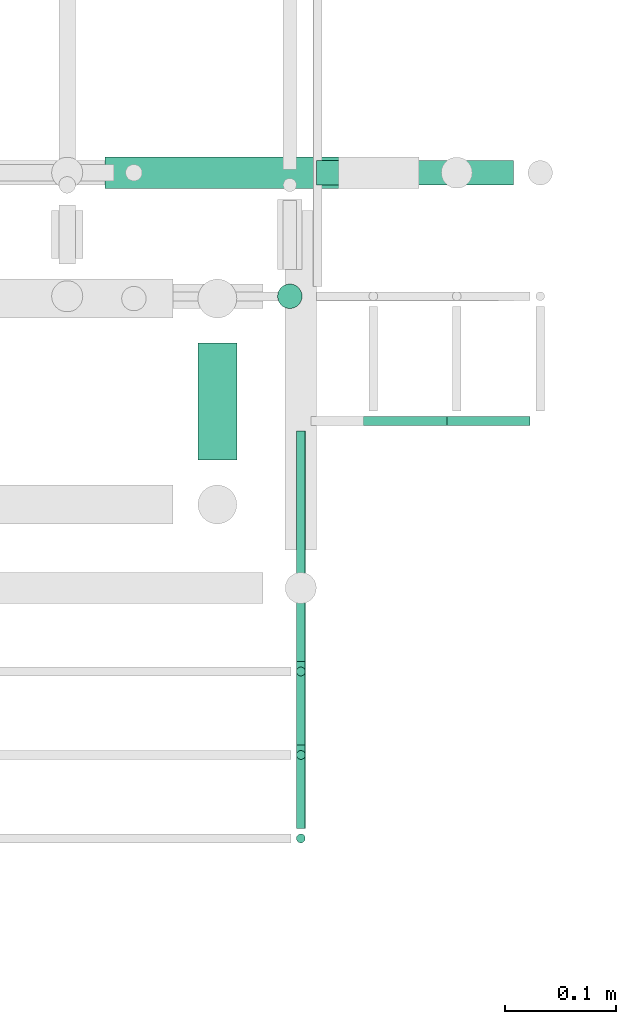
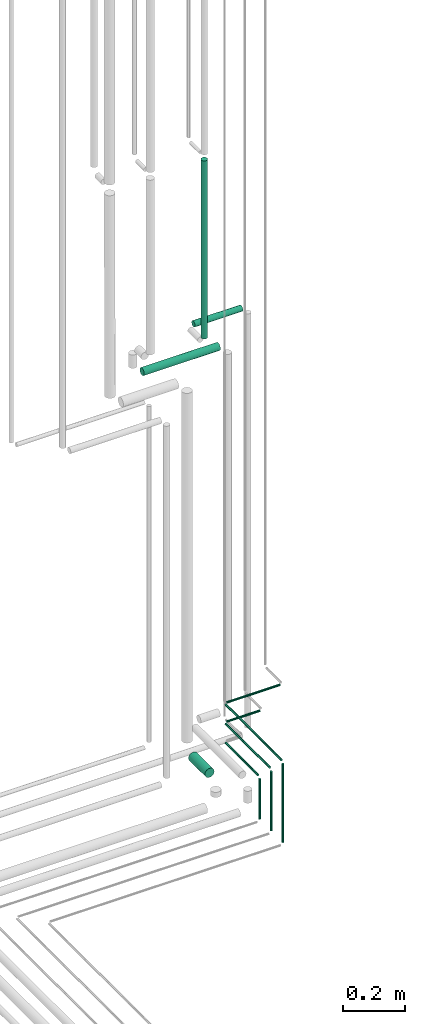
# One storey, part 235 of 331: 12 flow segments.
"""IFC2X3 building model written with IfcOpenShell, lengths in millimetres."""

from ifc_helpers import new_model, entity, si_unit, converted_unit, derived_unit, direction, frame, frame_2d, origin, origin_2d_with_axis, place, context, subcontext, project, spatial, circle, extrude, type_object, element, save


model = new_model("IFC2X3")

# Units and contexts
model_context = context("Model", 3, precision=0.01, world=origin(), true_north=direction((6.12303176911189e-17, 1.0)))
body_context = subcontext(model_context, "Body", "Model", "MODEL_VIEW")
ifc_project = project(units=[si_unit("LENGTHUNIT", "METRE", prefix="MILLI"), si_unit("AREAUNIT", "SQUARE_METRE"), si_unit("VOLUMEUNIT", "CUBIC_METRE"), converted_unit("PLANEANGLEUNIT", "DEGREE", entity("IfcRatioMeasure", 0.0174532925199433), si_unit("PLANEANGLEUNIT", "RADIAN"), dimensions=[0, 0, 0, 0, 0, 0, 0]), si_unit("MASSUNIT", "GRAM", prefix="KILO"), derived_unit("MASSDENSITYUNIT", [(si_unit("MASSUNIT", "GRAM", prefix="KILO"), 1), (si_unit("LENGTHUNIT", "METRE"), -3)]), derived_unit("MOMENTOFINERTIAUNIT", [(si_unit("LENGTHUNIT", "METRE"), 4)]), si_unit("TIMEUNIT", "SECOND"), si_unit("FREQUENCYUNIT", "HERTZ"), si_unit("THERMODYNAMICTEMPERATUREUNIT", "DEGREE_CELSIUS"), derived_unit("THERMALTRANSMITTANCEUNIT", [(si_unit("MASSUNIT", "GRAM", prefix="KILO"), 1), (si_unit("THERMODYNAMICTEMPERATUREUNIT", "KELVIN"), -1), (si_unit("TIMEUNIT", "SECOND"), -3)]), derived_unit("VOLUMETRICFLOWRATEUNIT", [(si_unit("LENGTHUNIT", "METRE"), 3), (si_unit("TIMEUNIT", "SECOND"), -1)]), derived_unit("MASSFLOWRATEUNIT", [(si_unit("MASSUNIT", "GRAM", prefix="KILO"), 1), (si_unit("TIMEUNIT", "SECOND"), -1)]), derived_unit("ROTATIONALFREQUENCYUNIT", [(si_unit("TIMEUNIT", "SECOND"), -1)]), si_unit("ELECTRICCURRENTUNIT", "AMPERE"), si_unit("ELECTRICVOLTAGEUNIT", "VOLT"), si_unit("POWERUNIT", "WATT"), si_unit("FORCEUNIT", "NEWTON", prefix="KILO"), si_unit("ILLUMINANCEUNIT", "LUX"), si_unit("LUMINOUSFLUXUNIT", "LUMEN"), si_unit("LUMINOUSINTENSITYUNIT", "CANDELA"), derived_unit("USERDEFINED", [(si_unit("MASSUNIT", "GRAM", prefix="KILO"), -1), (si_unit("LENGTHUNIT", "METRE"), -2), (si_unit("TIMEUNIT", "SECOND"), 3), (si_unit("LUMINOUSFLUXUNIT", "LUMEN"), 1)]), derived_unit("LINEARVELOCITYUNIT", [(si_unit("LENGTHUNIT", "METRE"), 1), (si_unit("TIMEUNIT", "SECOND"), -1)]), si_unit("PRESSUREUNIT", "PASCAL"), derived_unit("USERDEFINED", [(si_unit("LENGTHUNIT", "METRE"), -2), (si_unit("MASSUNIT", "GRAM", prefix="KILO"), 1), (si_unit("TIMEUNIT", "SECOND"), -2)]), derived_unit("LINEARFORCEUNIT", [(si_unit("MASSUNIT", "GRAM", prefix="KILO"), 1), (si_unit("LENGTHUNIT", "METRE"), 1), (si_unit("TIMEUNIT", "SECOND"), -2), (si_unit("LENGTHUNIT", "METRE"), -1)]), derived_unit("PLANARFORCEUNIT", [(si_unit("MASSUNIT", "GRAM", prefix="KILO"), 1), (si_unit("LENGTHUNIT", "METRE"), 1), (si_unit("TIMEUNIT", "SECOND"), -2), (si_unit("LENGTHUNIT", "METRE"), -2)])], contexts=[model_context])

# Site, building, storey
site_placement = place(None, frame((0.0, -0.00077364408347762, 0.0)))
site = spatial("IfcSite", under=ifc_project, at=site_placement, CompositionType="ELEMENT")
building_placement = place(site_placement, origin())
building = spatial("IfcBuilding", under=site, at=building_placement, CompositionType="ELEMENT")
storey_placement = place(building_placement, origin())
storey = spatial("IfcBuildingStorey", under=building, at=storey_placement, CompositionType="ELEMENT", Elevation=0.0)

# Flow segments
pipe_segment_type = type_object("IfcPipeSegmentType", PredefinedType="NOTDEFINED")
flow_segment_1_placement = place(building_placement, frame((66714.4020544242, 7821.93026688113, 2869.40472776409)))
element("IfcFlowSegment", 1, at=flow_segment_1_placement, inside=storey, type_object=pipe_segment_type, context=body_context, shape_type="SweptSolid", body=[
    extrude(circle(Radius=4.0, at=origin_2d_with_axis()), frame((5.59527223591499, 0.0, 5.59527223591607), z_axis=(0.0, 1.0, 0.0), x_axis=(1.0, 0.0, 0.0)), (0.0, 0.0, 1.0), 207.000000000003),
])
flow_segment_2_placement = place(building_placement, frame((66714.4020544242, 7746.93026688113, 2944.40472776408)))
element("IfcFlowSegment", 2, at=flow_segment_2_placement, inside=storey, type_object=pipe_segment_type, context=body_context, shape_type="SweptSolid", body=[
    extrude(circle(Radius=4.0, at=origin_2d_with_axis()), frame((5.59527223591499, 0.0, 5.59527223591607), z_axis=(0.0, 1.0, 0.0), x_axis=(-1.0, 0.0, 0.0)), (0.0, 0.0, 1.0), 282.000000000003),
])
flow_segment_3_placement = place(building_placement, frame((66714.4020544242, 7671.93026688114, 3019.40472776408)))
element("IfcFlowSegment", 3, at=flow_segment_3_placement, inside=storey, type_object=pipe_segment_type, context=body_context, shape_type="SweptSolid", body=[
    extrude(circle(Radius=4.0, at=frame_2d((-5.89322025031666e-39, -4.33146851719357e-12), x_axis=(1.0, 0.0))), frame((5.59527223591499, 0.0, 5.59527223591174), z_axis=(0.0, 1.0, 0.0), x_axis=(-1.0, 0.0, 0.0)), (0.0, 0.0, 1.0), 357.000000000002),
])
flow_segment_4_placement = place(building_placement, frame((66728.9973266601, 8032.33499464522, 3019.40472776408)))
element("IfcFlowSegment", 4, at=flow_segment_4_placement, inside=storey, type_object=pipe_segment_type, context=body_context, shape_type="SweptSolid", body=[
    extrude(circle(Radius=4.0, at=origin_2d_with_axis()), frame((0.0, 5.59527223591607, 5.59527223591607), z_axis=(1.0, 0.0, 0.0), x_axis=(0.0, -1.0, 0.0)), (0.0, 0.0, 1.0), 197.114556617545),
])
flow_segment_5_placement = place(building_placement, frame((66728.9973266601, 8032.33499464522, 2944.40472776408)))
element("IfcFlowSegment", 5, at=flow_segment_5_placement, inside=storey, type_object=pipe_segment_type, context=body_context, shape_type="SweptSolid", body=[
    extrude(circle(Radius=4.0, at=origin_2d_with_axis()), frame((0.0, 5.59527223591607, 5.59527223591607), z_axis=(1.0, 0.0, 0.0), x_axis=(0.0, -1.0, 0.0)), (0.0, 0.0, 1.0), 122.114556617519),
])
flow_segment_6_placement = place(building_placement, frame((66697.5166110417, 8137.40537015918, 4391.79602249762)))
element("IfcFlowSegment", 6, at=flow_segment_6_placement, inside=storey, type_object=pipe_segment_type, context=body_context, shape_type="SweptSolid", body=[
    extrude(circle(Radius=11.0, at=origin_2d_with_axis()), frame((12.5952722359134, 12.5952722359156, 0.0), z_axis=(0.0, 0.0, 1.0), x_axis=(-1.0, 0.0, 0.0)), (0.0, 0.0, 1.0), 696.203977502408),
])
flow_segment_7_placement = place(building_placement, frame((66625.9020544242, 8002.93026688114, 2780.90472776413)))
element("IfcFlowSegment", 7, at=flow_segment_7_placement, inside=storey, type_object=pipe_segment_type, context=body_context, shape_type="SweptSolid", body=[
    extrude(circle(Radius=17.5, at=origin_2d_with_axis()), frame((19.0952722359119, 0.0, 19.0952722359157), z_axis=(0.0, 1.0, 0.0), x_axis=(1.0, 0.0, 0.0)), (0.0, 0.0, 1.0), 104.999692491265),
])
flow_segment_8_placement = place(building_placement, frame((66544.1118832776, 8245.40537015938, 4232.20075026173)))
element("IfcFlowSegment", 8, at=flow_segment_8_placement, inside=storey, type_object=pipe_segment_type, context=body_context, shape_type="SweptSolid", body=[
    extrude(circle(Radius=14.0, at=frame_2d((1.08286712929839e-12, -1.16778300377151e-41), x_axis=(1.0, 0.0))), frame((0.0, 15.5952722359181, 15.595272235917), z_axis=(1.0, 0.0, 0.0), x_axis=(0.0, 1.0, 0.0)), (0.0, 0.0, 1.0), 281.999999999607),
])
flow_segment_9_placement = place(building_placement, frame((66734.1118832777, 8248.40537015914, 4355.20075026173)))
element("IfcFlowSegment", 9, at=flow_segment_9_placement, inside=storey, type_object=pipe_segment_type, context=body_context, shape_type="SweptSolid", body=[
    extrude(circle(Radius=11.0, at=frame_2d((-1.08286712929839e-12, 7.78522002512094e-42), x_axis=(1.0, 0.0))), frame((0.0, 12.5952722359166, 12.5952722359166), z_axis=(1.0, 0.0, 0.0), x_axis=(0.0, 1.0, 0.0)), (0.0, 0.0, 1.0), 177.00000000002),
])
flow_segment_10_placement = place(building_placement, frame((66714.4020544242, 7807.33499464522, 2709.0)))
element("IfcFlowSegment", 10, at=flow_segment_10_placement, inside=storey, type_object=pipe_segment_type, context=body_context, shape_type="SweptSolid", body=[
    extrude(circle(Radius=4.0, at=origin_2d_with_axis()), frame((5.59527223591499, 5.59527223591607, 0.0)), (0.0, 0.0, 1.0), 157.000000000011),
])
flow_segment_11_placement = place(building_placement, frame((66714.4020544242, 7732.33499464522, 2709.0)))
element("IfcFlowSegment", 11, at=flow_segment_11_placement, inside=storey, type_object=pipe_segment_type, context=body_context, shape_type="SweptSolid", body=[
    extrude(circle(Radius=4.0, at=origin_2d_with_axis()), frame((5.59527223591499, 5.59527223591607, 0.0)), (0.0, 0.0, 1.0), 232.000000000012),
])
flow_segment_12_placement = place(building_placement, frame((66714.4020544242, 7657.33499464522, 2709.0)))
element("IfcFlowSegment", 12, at=flow_segment_12_placement, inside=storey, type_object=pipe_segment_type, context=body_context, shape_type="SweptSolid", body=[
    extrude(circle(Radius=4.0, at=origin_2d_with_axis()), frame((5.59527223591499, 5.59527223591607, 0.0)), (0.0, 0.0, 1.0), 306.999999999991),
])

save(model, "model.ifc")
